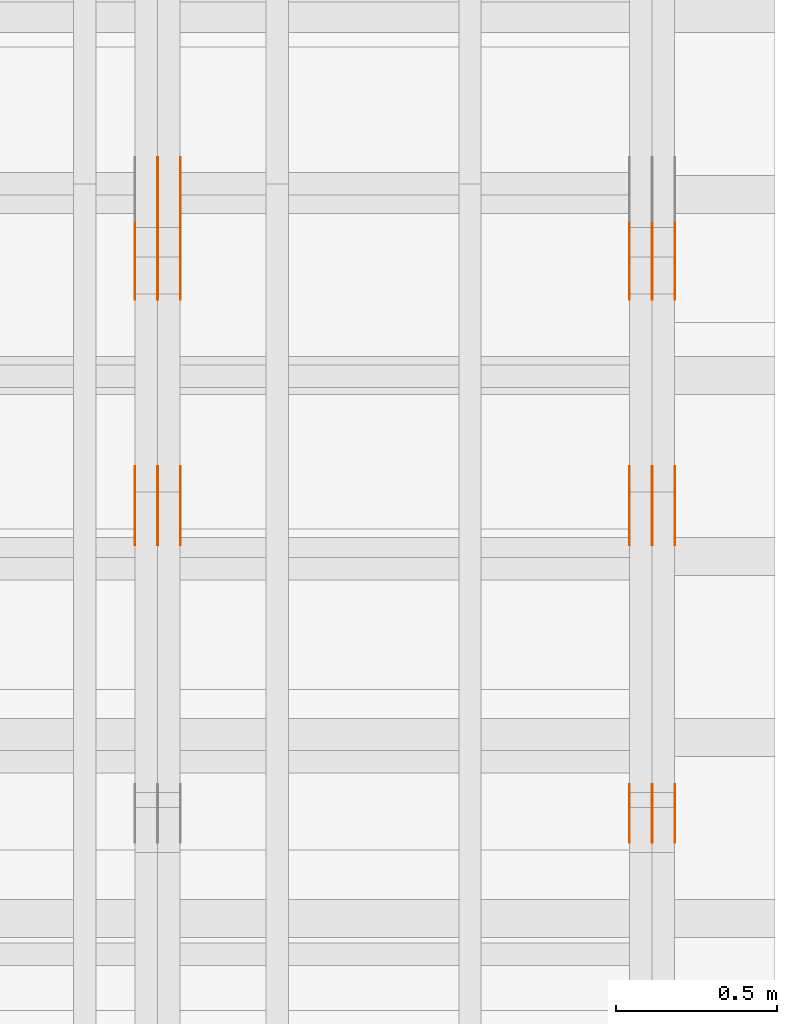
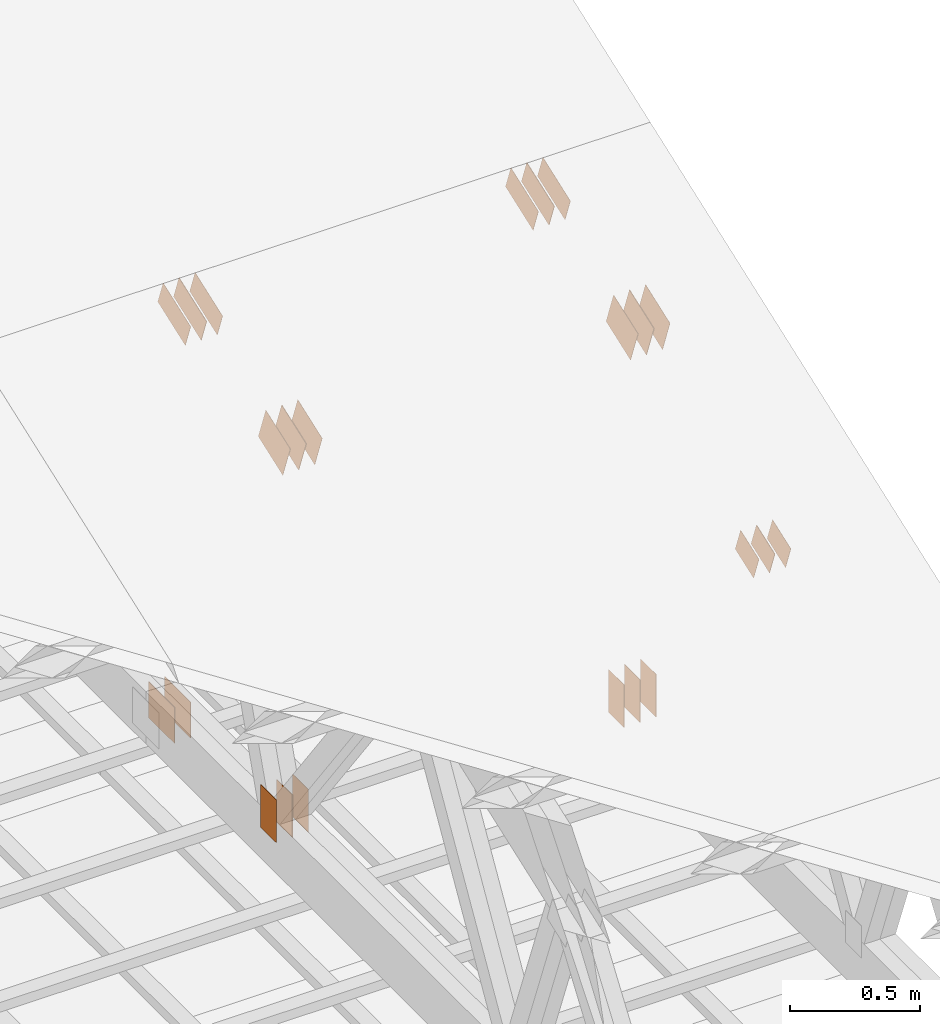
# One storey, part 155 of 189: 31 proxies.
"""IFC2X3 building model written with IfcOpenShell, lengths in millimetres."""

import ifcopenshell
import ifcopenshell.guid

model = None  # the IFC model being written
_history = None  # IfcOwnerHistory: only IFC2X3 demands one
_inside = {}  # id of a spatial element -> (the spatial element, [elements in it])
_under = {}  # id of a project, library or spatial element -> (it, [spatial elements below it])
_declared = {}  # id of a project -> (the project, [libraries it declares])
_typed = {}  # id of a type object -> (the type object, [elements of that type])
_made_of = {}  # id of a material, layer set ... -> (it, [elements and type objects made of it])


def new_model(schema):
    """Start an empty IFC model of exactly this schema.

    Asked for "IFC4X3", IfcOpenShell would pick the latest addendum, in which some entities
    have other attributes; the version numbers below select the first issue.
    IFC2X3 requires an IfcOwnerHistory on every rooted entity: one is made here for all.
    """
    global model, _history
    if schema == "IFC4X3":
        model = ifcopenshell.file(schema_version=(4, 3, 0, 0))
    else:
        model = ifcopenshell.file(schema=schema)
    _inside.clear()
    _under.clear()
    _declared.clear()
    _typed.clear()
    _made_of.clear()
    _history = None
    if model.schema == "IFC2X3":
        org = make("IfcOrganization", Name="unknown")
        user = make(
            "IfcPersonAndOrganization",
            ThePerson=make("IfcPerson", FamilyName="unknown"),
            TheOrganization=org,
        )
        app = make(
            "IfcApplication",
            ApplicationDeveloper=org,
            Version="unknown",
            ApplicationFullName="unknown",
            ApplicationIdentifier="unknown",
        )
        _history = make(
            "IfcOwnerHistory",
            OwningUser=user,
            OwningApplication=app,
            ChangeAction="ADDED",
            CreationDate=0,
        )
    return model


def make(cls, **values):
    """One entity of the class cls with the attributes given. An attribute that is None is left unset."""
    return model.create_entity(
        cls, **{name: value for name, value in values.items() if value is not None}
    )


def entity(cls, *values):
    """Any entity or typed value of the class cls, its attributes in the order of the schema. None: left unset."""
    e = model.create_entity(cls)
    for i, value in enumerate(values):
        if value is not None:
            e[i] = value
    return e


def rooted(cls, **values):
    """An entity with a GlobalId (a new one), such as an element, a storey or a relation."""
    return make(cls, GlobalId=ifcopenshell.guid.new(), OwnerHistory=_history, **values)


def si_unit(unit_type, name, prefix=None):
    """IfcSIUnit, for example si_unit("LENGTHUNIT", "METRE", prefix="MILLI")."""
    return make("IfcSIUnit", UnitType=unit_type, Prefix=prefix, Name=name)


def converted_unit(unit_type, name, factor, base, dimensions=None, offset=None):
    """IfcConversionBasedUnit, such as the inch: factor (a typed value) times the base unit."""
    return make(
        "IfcConversionBasedUnit"
        if offset is None
        else "IfcConversionBasedUnitWithOffset",
        ConversionOffset=offset,
        Dimensions=None
        if dimensions is None
        else entity("IfcDimensionalExponents", *dimensions),
        UnitType=unit_type,
        Name=name,
        ConversionFactor=make(
            "IfcMeasureWithUnit", ValueComponent=factor, UnitComponent=base
        ),
    )


def derived_unit(unit_type, elements):
    """IfcDerivedUnit: a product of units, each with its exponent."""
    return make(
        "IfcDerivedUnit",
        Elements=[
            make("IfcDerivedUnitElement", Unit=unit, Exponent=power)
            for unit, power in elements
        ],
        UnitType=unit_type,
    )


def assignment(units):
    """IfcUnitAssignment: the units of a project."""
    return None if units is None else make("IfcUnitAssignment", Units=units)


def point(xyz):
    """IfcCartesianPoint."""
    return None if xyz is None else make("IfcCartesianPoint", Coordinates=xyz)


def direction(xyz):
    """IfcDirection."""
    return None if xyz is None else make("IfcDirection", DirectionRatios=xyz)


def frame(location, z_axis=None, x_axis=None):
    """IfcAxis2Placement3D, a coordinate frame: its origin and axes. An axis left out is left unset."""
    return make(
        "IfcAxis2Placement3D",
        Location=point(location),
        Axis=direction(z_axis),
        RefDirection=direction(x_axis),
    )


def frame_2d(location, x_axis=None):
    """IfcAxis2Placement2D, a coordinate frame in the plane: its origin and x axis."""
    return make(
        "IfcAxis2Placement2D", Location=point(location), RefDirection=direction(x_axis)
    )


def origin():
    """The frame at (0, 0, 0) with its axes left unset."""
    return frame((0.0, 0.0, 0.0))


def origin_2d_with_axis():
    """The frame at (0, 0) in the plane with the x axis (1, 0) written out."""
    return frame_2d((0.0, 0.0), x_axis=(1.0, 0.0))


def place(relative_to, where):
    """IfcLocalPlacement: puts the frame where relative to a parent placement (None: the world)."""
    return make(
        "IfcLocalPlacement", PlacementRelTo=relative_to, RelativePlacement=where
    )


def context(
    kind, dimensions, precision=None, world=None, true_north=None, identifier=None
):
    """IfcGeometricRepresentationContext, for example the 3D "Model" context."""
    return make(
        "IfcGeometricRepresentationContext",
        ContextIdentifier=identifier,
        ContextType=kind,
        CoordinateSpaceDimension=dimensions,
        Precision=precision,
        WorldCoordinateSystem=world,
        TrueNorth=true_north,
    )


def subcontext(parent, identifier, kind, view, scale=None):
    """IfcGeometricRepresentationSubContext, for example "Body" below "Model"."""
    return make(
        "IfcGeometricRepresentationSubContext",
        ContextIdentifier=identifier,
        ContextType=kind,
        ParentContext=parent,
        TargetScale=scale,
        TargetView=view,
    )


def project(units=None, contexts=None):
    """IfcProject with its units and contexts."""
    return rooted(
        "IfcProject",
        Name="project",
        RepresentationContexts=contexts,
        UnitsInContext=assignment(units),
    )


def spatial(cls, under=None, at=None, **own):
    """A site, building, storey or space (cls), placed at a placement, below another one or the project."""
    s = rooted(cls, ObjectPlacement=at, **own)
    if under is not None:
        _under.setdefault(under.id(), (under, []))[1].append(s)
    return s


def polyline(points):
    """IfcPolyline through the points."""
    return make("IfcPolyline", Points=[point(p) for p in points])


def profile(cls, at=None, kind="AREA", **sizes):
    """A parametric profile (cls). Its sizes go by their IFC names, for example OverallWidth=200.0."""
    return make(cls, ProfileType=kind, Position=at, **sizes)


def rectangle(**sizes):
    """IfcRectangleProfileDef."""
    return profile("IfcRectangleProfileDef", **sizes)


def outline(outer, holes=None, kind="AREA"):
    """IfcArbitraryClosedProfileDef: a profile drawn as a closed curve; with holes, ...WithVoids."""
    if holes is None:
        return make("IfcArbitraryClosedProfileDef", ProfileType=kind, OuterCurve=outer)
    return make(
        "IfcArbitraryProfileDefWithVoids",
        ProfileType=kind,
        OuterCurve=outer,
        InnerCurves=holes,
    )


def extrude(swept, where, along, depth):
    """IfcExtrudedAreaSolid: the profile swept, set in the frame where, extruded along a direction by depth."""
    return make(
        "IfcExtrudedAreaSolid",
        SweptArea=swept,
        Position=where,
        ExtrudedDirection=direction(along),
        Depth=depth,
    )


def shape(context_of_items, identifier, shape_type, items):
    """IfcShapeRepresentation: the items that make up one representation, for example the "Body"."""
    return make(
        "IfcShapeRepresentation",
        ContextOfItems=context_of_items,
        RepresentationIdentifier=identifier,
        RepresentationType=shape_type,
        Items=items,
    )


def source(mapping_origin, context_of_items, identifier, shape_type, items):
    """IfcRepresentationMap: a shape defined once, which mapped items show again and again."""
    return make(
        "IfcRepresentationMap",
        MappingOrigin=mapping_origin,
        MappedRepresentation=shape(context_of_items, identifier, shape_type, items),
    )


def transform(
    local_origin,
    x_axis=None,
    y_axis=None,
    z_axis=None,
    scale=None,
    scale2=None,
    scale3=None,
    uniform=True,
):
    """IfcCartesianTransformationOperator3D, or its non-uniform kind. x_axis, y_axis, z_axis: its Axis1, 2, 3."""
    if uniform:
        return make(
            "IfcCartesianTransformationOperator3D",
            Axis1=direction(x_axis),
            Axis2=direction(y_axis),
            LocalOrigin=point(local_origin),
            Scale=scale,
            Axis3=direction(z_axis),
        )
    return make(
        "IfcCartesianTransformationOperator3DnonUniform",
        Axis1=direction(x_axis),
        Axis2=direction(y_axis),
        LocalOrigin=point(local_origin),
        Scale=scale,
        Axis3=direction(z_axis),
        Scale2=scale2,
        Scale3=scale3,
    )


def mapped(mapping_source, mapping_target):
    """IfcMappedItem: shows the shape of a source again, moved by a transform."""
    return make(
        "IfcMappedItem", MappingSource=mapping_source, MappingTarget=mapping_target
    )


def material(Name=None, Category=None):
    """IfcMaterial."""
    return make("IfcMaterial", Name=Name, Category=Category)


def made_of(thing, what):
    """Note that an element or type object is made of a material, layer set ...; save() writes the relation."""
    if what is not None:
        _made_of.setdefault(what.id(), (what, []))[1].append(thing)
    return thing


def type_object(cls, material=None, **own):
    """A type object (cls), such as IfcWallType, which elements share."""
    return made_of(rooted(cls, **own), material)


def type_shapes(of_type, sources):
    """Give a type object the sources (RepresentationMaps) that its elements show as mapped items."""
    of_type.RepresentationMaps = sources


def element(
    cls,
    number,
    at=None,
    inside=None,
    cuts=None,
    type_object=None,
    material=None,
    context=None,
    identifier="Body",
    shape_type=None,
    held_by="IfcProductDefinitionShape",
    body=None,
    shapes=None,
    **own,
):
    """One element of the class cls, such as IfcWall. Its Tag is "e" and its number.

    at: its placement. inside: the storey or other place that contains it. cuts: it is an
    opening in that element (IfcRelVoidsElement). A single representation is given by context,
    identifier, shape_type and body (its items); several are given by shapes. held_by: the class
    of the entity that holds the representations. save() writes the other relations.
    """
    e = rooted(cls, Tag="e%d" % number, ObjectPlacement=at, **own)
    if body is not None:
        shapes = [shape(context, identifier, shape_type, body)]
    if shapes is not None:
        e.Representation = make(held_by, Representations=shapes)
    if inside is not None:
        _inside.setdefault(inside.id(), (inside, []))[1].append(e)
    if cuts is not None:
        rooted(
            "IfcRelVoidsElement", RelatingBuildingElement=cuts, RelatedOpeningElement=e
        )
    if type_object is not None:
        _typed.setdefault(type_object.id(), (type_object, []))[1].append(e)
    return made_of(e, material)


def aggregate(whole, parts):
    """IfcRelAggregates: a whole, such as a stair, and the parts it consists of."""
    return rooted("IfcRelAggregates", RelatingObject=whole, RelatedObjects=parts)


def save(model, path):
    """Write the relations noted so far, then the file.

    IfcRelAggregates (storeys below a building ...), IfcRelContainedInSpatialStructure (elements
    in a storey), IfcRelDefinesByType, IfcRelAssociatesMaterial and IfcRelDeclares: one each for
    every whole, place, type object, material and project.
    """
    for whole, parts in _under.values():
        aggregate(whole, parts)
    for where, things in _inside.values():
        rooted(
            "IfcRelContainedInSpatialStructure",
            RelatedElements=things,
            RelatingStructure=where,
        )
    for kind, things in _typed.values():
        rooted("IfcRelDefinesByType", RelatedObjects=things, RelatingType=kind)
    for what, things in _made_of.values():
        rooted("IfcRelAssociatesMaterial", RelatedObjects=things, RelatingMaterial=what)
    for by, libraries in _declared.values():
        rooted("IfcRelDeclares", RelatingContext=by, RelatedDefinitions=libraries)
    model.write(path)


model = new_model("IFC2X3")

# Units and contexts
model_context = context("Model", 3, precision=0.01, world=origin(), true_north=direction((6.12303176911189e-17, 1.0)))
body_context = subcontext(model_context, "Body", "Model", "MODEL_VIEW")
ifc_project = project(units=[si_unit("LENGTHUNIT", "METRE", prefix="MILLI"), si_unit("AREAUNIT", "SQUARE_METRE"), si_unit("VOLUMEUNIT", "CUBIC_METRE"), converted_unit("PLANEANGLEUNIT", "DEGREE", entity("IfcRatioMeasure", 0.0174532925199433), si_unit("PLANEANGLEUNIT", "RADIAN"), dimensions=[0, 0, 0, 0, 0, 0, 0]), si_unit("MASSUNIT", "GRAM", prefix="KILO"), derived_unit("MASSDENSITYUNIT", [(si_unit("MASSUNIT", "GRAM", prefix="KILO"), 1), (si_unit("LENGTHUNIT", "METRE"), -3)]), si_unit("TIMEUNIT", "SECOND"), si_unit("FREQUENCYUNIT", "HERTZ"), si_unit("THERMODYNAMICTEMPERATUREUNIT", "DEGREE_CELSIUS"), derived_unit("THERMALTRANSMITTANCEUNIT", [(si_unit("MASSUNIT", "GRAM", prefix="KILO"), 1), (si_unit("THERMODYNAMICTEMPERATUREUNIT", "KELVIN"), -1), (si_unit("TIMEUNIT", "SECOND"), -3)]), derived_unit("VOLUMETRICFLOWRATEUNIT", [(si_unit("LENGTHUNIT", "METRE"), 3), (si_unit("TIMEUNIT", "SECOND"), -1)]), si_unit("ELECTRICCURRENTUNIT", "AMPERE"), si_unit("ELECTRICVOLTAGEUNIT", "VOLT"), si_unit("POWERUNIT", "WATT"), si_unit("FORCEUNIT", "NEWTON"), si_unit("ILLUMINANCEUNIT", "LUX"), si_unit("LUMINOUSFLUXUNIT", "LUMEN"), si_unit("LUMINOUSINTENSITYUNIT", "CANDELA"), derived_unit("USERDEFINED", [(si_unit("MASSUNIT", "GRAM", prefix="KILO"), -1), (si_unit("LENGTHUNIT", "METRE"), -2), (si_unit("TIMEUNIT", "SECOND"), 3), (si_unit("LUMINOUSFLUXUNIT", "LUMEN"), 1)]), derived_unit("LINEARVELOCITYUNIT", [(si_unit("LENGTHUNIT", "METRE"), 1), (si_unit("TIMEUNIT", "SECOND"), -1)]), si_unit("PRESSUREUNIT", "PASCAL"), derived_unit("USERDEFINED", [(si_unit("LENGTHUNIT", "METRE"), -2), (si_unit("MASSUNIT", "GRAM", prefix="KILO"), 1), (si_unit("TIMEUNIT", "SECOND"), -2)])], contexts=[model_context])

# Site, building, storey
site_placement = place(None, origin())
site = spatial("IfcSite", under=ifc_project, at=site_placement, CompositionType="ELEMENT")
building_placement = place(site_placement, origin())
building = spatial("IfcBuilding", under=site, at=building_placement, CompositionType="ELEMENT")
storey_placement = place(building_placement, origin())
storey = spatial("IfcBuildingStorey", under=building, at=storey_placement, Name="Default", CompositionType="ELEMENT", Elevation=0.0)

# Proxies
ifc_material_1 = material(Name="IfcSurfaceStyle #280396")
building_element_proxy_type_1 = type_object("IfcBuildingElementProxyType", PredefinedType="NOTDEFINED", material=ifc_material_1)
shared_shape_1 = source(origin(), body_context, "Body", "SweptSolid", [
    extrude(outline(polyline([(-112.500654374667, -59.9999021691247), (112.500117969231, -59.9999021691247), (112.500612624162, 59.9999021691247), (-112.500076218726, 59.9999021691247), (-112.500654374667, -59.9999021691247)])), frame((112.500612624162, 60.0003514046321, 0.0), z_axis=(0.0, 0.0, 1.0), x_axis=(-1.0, 0.0, 0.0)), (0.0, 0.0, 1.0), 1.3),
])
type_shapes(building_element_proxy_type_1, [shared_shape_1])
proxy_1_placement = place(building_placement, frame((49841.3, 5418.0703125, 2162.37353515625), z_axis=(-1.0, 0.0, 0.0), x_axis=(0.0, 0.939692620785908, 0.342020143325669)))
element("IfcBuildingElementProxy", 1, at=proxy_1_placement, inside=storey, type_object=building_element_proxy_type_1, material=ifc_material_1, context=body_context, shape_type="MappedRepresentation", body=[
    mapped(shared_shape_1, transform((0.0, 0.0, 0.0), scale=1.0)),
])
ifc_material_2 = material(Name="IfcSurfaceStyle #280339")
building_element_proxy_type_2 = type_object("IfcBuildingElementProxyType", PredefinedType="NOTDEFINED", material=ifc_material_2)
shared_shape_2 = source(origin(), body_context, "Body", "SweptSolid", [
    extrude(outline(polyline([(-112.500654374667, -59.9999021691247), (112.500117969231, -59.9999021691247), (112.500612624162, 59.9999021691247), (-112.500076218726, 59.9999021691247), (-112.500654374667, -59.9999021691247)])), frame((112.500612624162, 60.0003514046321, 0.0), z_axis=(0.0, 0.0, 1.0), x_axis=(-1.0, 0.0, 0.0)), (0.0, 0.0, 1.0), 1.29999999999998),
])
type_shapes(building_element_proxy_type_2, [shared_shape_2])
proxy_2_placement = place(building_placement, frame((49770.0, 5418.0703125, 2162.37353515625), z_axis=(-1.0, 0.0, 0.0), x_axis=(0.0, 0.939692620785908, 0.342020143325669)))
element("IfcBuildingElementProxy", 2, at=proxy_2_placement, inside=storey, type_object=building_element_proxy_type_2, material=ifc_material_2, context=body_context, shape_type="MappedRepresentation", body=[
    mapped(shared_shape_2, transform((0.0, 0.0, 0.0), scale=1.0)),
])
ifc_material_3 = material(Name="IfcSurfaceStyle #280282")
building_element_proxy_type_3 = type_object("IfcBuildingElementProxyType", PredefinedType="NOTDEFINED", material=ifc_material_3)
shared_shape_3 = source(origin(), body_context, "Body", "SweptSolid", [
    extrude(outline(polyline([(-112.500654374667, -59.9999021691247), (112.500117969231, -59.9999021691247), (112.500612624162, 59.9999021691247), (-112.500076218726, 59.9999021691247), (-112.500654374667, -59.9999021691247)])), frame((112.500612624162, 60.0003514046321, 0.0), z_axis=(0.0, 0.0, 1.0), x_axis=(-1.0, 0.0, 0.0)), (0.0, 0.0, 1.0), 1.29999999999998),
])
type_shapes(building_element_proxy_type_3, [shared_shape_3])
proxy_3_placement = place(building_placement, frame((49771.3, 5418.0703125, 2162.37353515625), z_axis=(-1.0, 0.0, 0.0), x_axis=(0.0, 0.939692620785908, 0.342020143325669)))
element("IfcBuildingElementProxy", 3, at=proxy_3_placement, inside=storey, type_object=building_element_proxy_type_3, material=ifc_material_3, context=body_context, shape_type="MappedRepresentation", body=[
    mapped(shared_shape_3, transform((0.0, 0.0, 0.0), scale=1.0)),
])
ifc_material_4 = material(Name="IfcSurfaceStyle #280225")
building_element_proxy_type_4 = type_object("IfcBuildingElementProxyType", PredefinedType="NOTDEFINED", material=ifc_material_4)
shared_shape_4 = source(origin(), body_context, "Body", "SweptSolid", [
    extrude(outline(polyline([(-112.500654374667, -59.9999021691247), (112.500117969231, -59.9999021691247), (112.500612624162, 59.9999021691247), (-112.500076218726, 59.9999021691247), (-112.500654374667, -59.9999021691247)])), frame((112.500612624162, 60.0003514046321, 0.0), z_axis=(0.0, 0.0, 1.0), x_axis=(-1.0, 0.0, 0.0)), (0.0, 0.0, 1.0), 1.29999999999999),
])
type_shapes(building_element_proxy_type_4, [shared_shape_4])
proxy_4_placement = place(building_placement, frame((49700.0, 5418.0703125, 2162.37353515625), z_axis=(-1.0, 0.0, 0.0), x_axis=(0.0, 0.939692620785908, 0.342020143325669)))
element("IfcBuildingElementProxy", 4, at=proxy_4_placement, inside=storey, type_object=building_element_proxy_type_4, material=ifc_material_4, context=body_context, shape_type="MappedRepresentation", body=[
    mapped(shared_shape_4, transform((0.0, 0.0, 0.0), scale=1.0)),
])
ifc_material_5 = material(Name="IfcSurfaceStyle #279712")
building_element_proxy_type_5 = type_object("IfcBuildingElementProxyType", PredefinedType="NOTDEFINED", material=ifc_material_5)
shared_shape_5 = source(origin(), body_context, "Body", "SweptSolid", [
    extrude(rectangle(XDim=200.0, YDim=120.0, at=origin_2d_with_axis()), frame((100.0, 60.0, 0.0), z_axis=(0.0, 0.0, 1.0), x_axis=(-1.0, 0.0, 0.0)), (0.0, 0.0, 1.0), 1.3),
])
type_shapes(building_element_proxy_type_5, [shared_shape_5])
proxy_5_placement = place(building_placement, frame((49841.3, 4760.65625, 145.0), z_axis=(-1.0, 0.0, 0.0), x_axis=(0.0, 0.0, 1.0)))
element("IfcBuildingElementProxy", 5, at=proxy_5_placement, inside=storey, type_object=building_element_proxy_type_5, material=ifc_material_5, context=body_context, shape_type="MappedRepresentation", body=[
    mapped(shared_shape_5, transform((0.0, 0.0, 0.0), scale=1.0)),
])
ifc_material_6 = material(Name="IfcSurfaceStyle #279655")
building_element_proxy_type_6 = type_object("IfcBuildingElementProxyType", PredefinedType="NOTDEFINED", material=ifc_material_6)
shared_shape_6 = source(origin(), body_context, "Body", "SweptSolid", [
    extrude(rectangle(XDim=200.0, YDim=120.0, at=origin_2d_with_axis()), frame((100.0, 60.0, 0.0), z_axis=(0.0, 0.0, 1.0), x_axis=(-1.0, 0.0, 0.0)), (0.0, 0.0, 1.0), 1.29999999999998),
])
type_shapes(building_element_proxy_type_6, [shared_shape_6])
proxy_6_placement = place(building_placement, frame((49770.0, 4760.65625, 145.0), z_axis=(-1.0, 0.0, 0.0), x_axis=(0.0, 0.0, 1.0)))
element("IfcBuildingElementProxy", 6, at=proxy_6_placement, inside=storey, type_object=building_element_proxy_type_6, material=ifc_material_6, context=body_context, shape_type="MappedRepresentation", body=[
    mapped(shared_shape_6, transform((0.0, 0.0, 0.0), scale=1.0)),
])
ifc_material_7 = material(Name="IfcSurfaceStyle #279598")
building_element_proxy_type_7 = type_object("IfcBuildingElementProxyType", PredefinedType="NOTDEFINED", material=ifc_material_7)
shared_shape_7 = source(origin(), body_context, "Body", "SweptSolid", [
    extrude(rectangle(XDim=200.0, YDim=120.0, at=origin_2d_with_axis()), frame((100.0, 60.0, 0.0), z_axis=(0.0, 0.0, 1.0), x_axis=(-1.0, 0.0, 0.0)), (0.0, 0.0, 1.0), 1.29999999999998),
])
type_shapes(building_element_proxy_type_7, [shared_shape_7])
proxy_7_placement = place(building_placement, frame((49771.3, 4760.65625, 145.0), z_axis=(-1.0, 0.0, 0.0), x_axis=(0.0, 0.0, 1.0)))
element("IfcBuildingElementProxy", 7, at=proxy_7_placement, inside=storey, type_object=building_element_proxy_type_7, material=ifc_material_7, context=body_context, shape_type="MappedRepresentation", body=[
    mapped(shared_shape_7, transform((0.0, 0.0, 0.0), scale=1.0)),
])
ifc_material_8 = material(Name="IfcSurfaceStyle #279541")
building_element_proxy_type_8 = type_object("IfcBuildingElementProxyType", PredefinedType="NOTDEFINED", material=ifc_material_8)
shared_shape_8 = source(origin(), body_context, "Body", "SweptSolid", [
    extrude(rectangle(XDim=200.0, YDim=120.0, at=origin_2d_with_axis()), frame((100.0, 60.0, 0.0), z_axis=(0.0, 0.0, 1.0), x_axis=(-1.0, 0.0, 0.0)), (0.0, 0.0, 1.0), 1.29999999999999),
])
type_shapes(building_element_proxy_type_8, [shared_shape_8])
proxy_8_placement = place(building_placement, frame((49700.0, 4760.65625, 145.0), z_axis=(-1.0, 0.0, 0.0), x_axis=(0.0, 0.0, 1.0)))
element("IfcBuildingElementProxy", 8, at=proxy_8_placement, inside=storey, type_object=building_element_proxy_type_8, material=ifc_material_8, context=body_context, shape_type="MappedRepresentation", body=[
    mapped(shared_shape_8, transform((0.0, 0.0, 0.0), scale=1.0)),
])
ifc_material_9 = material(Name="IfcSurfaceStyle #279484")
building_element_proxy_type_9 = type_object("IfcBuildingElementProxyType", PredefinedType="NOTDEFINED", material=ifc_material_9)
shared_shape_9 = source(origin(), body_context, "Body", "SweptSolid", [
    extrude(outline(polyline([(-74.9994515581384, -59.9999039432178), (74.9998536965286, -59.9999039432178), (75.0003483514593, 59.9999039432178), (-75.0007504898495, 59.9999039432178), (-74.9994515581384, -59.9999039432178)])), frame((75.0003483514593, 60.0003496305408, 0.0), z_axis=(0.0, 0.0, 1.0), x_axis=(-1.0, 0.0, 0.0)), (0.0, 0.0, 1.0), 1.3),
])
type_shapes(building_element_proxy_type_9, [shared_shape_9])
proxy_9_placement = place(building_placement, frame((49841.3, 3726.8984375, 1559.607421875), z_axis=(-1.0, 0.0, 0.0), x_axis=(0.0, 0.939692620785908, 0.342020143325669)))
element("IfcBuildingElementProxy", 9, at=proxy_9_placement, inside=storey, type_object=building_element_proxy_type_9, material=ifc_material_9, context=body_context, shape_type="MappedRepresentation", body=[
    mapped(shared_shape_9, transform((0.0, 0.0, 0.0), scale=1.0)),
])
ifc_material_10 = material(Name="IfcSurfaceStyle #279427")
building_element_proxy_type_10 = type_object("IfcBuildingElementProxyType", PredefinedType="NOTDEFINED", material=ifc_material_10)
shared_shape_10 = source(origin(), body_context, "Body", "SweptSolid", [
    extrude(outline(polyline([(-74.9994515581384, -59.9999039432178), (74.9998536965286, -59.9999039432178), (75.0003483514593, 59.9999039432178), (-75.0007504898495, 59.9999039432178), (-74.9994515581384, -59.9999039432178)])), frame((75.0003483514593, 60.0003496305408, 0.0), z_axis=(0.0, 0.0, 1.0), x_axis=(-1.0, 0.0, 0.0)), (0.0, 0.0, 1.0), 1.29999999999999),
])
type_shapes(building_element_proxy_type_10, [shared_shape_10])
proxy_10_placement = place(building_placement, frame((49770.0, 3726.8984375, 1559.607421875), z_axis=(-1.0, 0.0, 0.0), x_axis=(0.0, 0.939692620785908, 0.342020143325669)))
element("IfcBuildingElementProxy", 10, at=proxy_10_placement, inside=storey, type_object=building_element_proxy_type_10, material=ifc_material_10, context=body_context, shape_type="MappedRepresentation", body=[
    mapped(shared_shape_10, transform((0.0, 0.0, 0.0), scale=1.0)),
])
ifc_material_11 = material(Name="IfcSurfaceStyle #279370")
building_element_proxy_type_11 = type_object("IfcBuildingElementProxyType", PredefinedType="NOTDEFINED", material=ifc_material_11)
shared_shape_11 = source(origin(), body_context, "Body", "SweptSolid", [
    extrude(outline(polyline([(-74.9994515581384, -59.9999039432178), (74.9998536965286, -59.9999039432178), (75.0003483514593, 59.9999039432178), (-75.0007504898495, 59.9999039432178), (-74.9994515581384, -59.9999039432178)])), frame((75.0003483514593, 60.0003496305408, 0.0), z_axis=(0.0, 0.0, 1.0), x_axis=(-1.0, 0.0, 0.0)), (0.0, 0.0, 1.0), 1.29999999999999),
])
type_shapes(building_element_proxy_type_11, [shared_shape_11])
proxy_11_placement = place(building_placement, frame((49771.3, 3726.8984375, 1559.607421875), z_axis=(-1.0, 0.0, 0.0), x_axis=(0.0, 0.939692620785908, 0.342020143325669)))
element("IfcBuildingElementProxy", 11, at=proxy_11_placement, inside=storey, type_object=building_element_proxy_type_11, material=ifc_material_11, context=body_context, shape_type="MappedRepresentation", body=[
    mapped(shared_shape_11, transform((0.0, 0.0, 0.0), scale=1.0)),
])
ifc_material_12 = material(Name="IfcSurfaceStyle #279313")
building_element_proxy_type_12 = type_object("IfcBuildingElementProxyType", PredefinedType="NOTDEFINED", material=ifc_material_12)
shared_shape_12 = source(origin(), body_context, "Body", "SweptSolid", [
    extrude(outline(polyline([(-74.9994515581384, -59.9999039432178), (74.9998536965286, -59.9999039432178), (75.0003483514593, 59.9999039432178), (-75.0007504898495, 59.9999039432178), (-74.9994515581384, -59.9999039432178)])), frame((75.0003483514593, 60.0003496305408, 0.0), z_axis=(0.0, 0.0, 1.0), x_axis=(-1.0, 0.0, 0.0)), (0.0, 0.0, 1.0), 1.29999999999999),
])
type_shapes(building_element_proxy_type_12, [shared_shape_12])
proxy_12_placement = place(building_placement, frame((49700.0, 3726.8984375, 1559.607421875), z_axis=(-1.0, 0.0, 0.0), x_axis=(0.0, 0.939692620785908, 0.342020143325669)))
element("IfcBuildingElementProxy", 12, at=proxy_12_placement, inside=storey, type_object=building_element_proxy_type_12, material=ifc_material_12, context=body_context, shape_type="MappedRepresentation", body=[
    mapped(shared_shape_12, transform((0.0, 0.0, 0.0), scale=1.0)),
])
ifc_material_13 = material(Name="IfcSurfaceStyle #274816")
building_element_proxy_type_13 = type_object("IfcBuildingElementProxyType", PredefinedType="NOTDEFINED", material=ifc_material_13)
shared_shape_13 = source(origin(), body_context, "Body", "SweptSolid", [
    extrude(outline(polyline([(-99.9993269270171, -84.0000832532405), (99.9997189122032, -84.0000832532405), (99.9992851765118, 84.0000832532405), (-99.999677161698, 84.0000832532405), (-99.9993269270171, -84.0000832532405)])), frame((99.9999283659736, 84.0000832532405, 0.0), z_axis=(0.0, 0.0, 1.0), x_axis=(-1.0, 0.0, 0.0)), (0.0, 0.0, 1.0), 1.3),
])
type_shapes(building_element_proxy_type_13, [shared_shape_13])
proxy_13_placement = place(building_placement, frame((49841.3, 4654.06379965055, 2052.96988554922), z_axis=(-1.0, 0.0, 0.0), x_axis=(0.0, 0.939692620785908, 0.342020143325669)))
element("IfcBuildingElementProxy", 13, at=proxy_13_placement, inside=storey, type_object=building_element_proxy_type_13, material=ifc_material_13, context=body_context, shape_type="MappedRepresentation", body=[
    mapped(shared_shape_13, transform((0.0, 0.0, 0.0), scale=1.0)),
])
ifc_material_14 = material(Name="IfcSurfaceStyle #274759")
building_element_proxy_type_14 = type_object("IfcBuildingElementProxyType", PredefinedType="NOTDEFINED", material=ifc_material_14)
shared_shape_14 = source(origin(), body_context, "Body", "SweptSolid", [
    extrude(outline(polyline([(-99.9993269270171, -84.0000832532405), (99.9997189122032, -84.0000832532405), (99.9992851765118, 84.0000832532405), (-99.999677161698, 84.0000832532405), (-99.9993269270171, -84.0000832532405)])), frame((99.9999283659736, 84.0000832532405, 0.0), z_axis=(0.0, 0.0, 1.0), x_axis=(-1.0, 0.0, 0.0)), (0.0, 0.0, 1.0), 1.29999999999998),
])
type_shapes(building_element_proxy_type_14, [shared_shape_14])
proxy_14_placement = place(building_placement, frame((49770.0, 4654.06379965055, 2052.96988554922), z_axis=(-1.0, 0.0, 0.0), x_axis=(0.0, 0.939692620785908, 0.342020143325669)))
element("IfcBuildingElementProxy", 14, at=proxy_14_placement, inside=storey, type_object=building_element_proxy_type_14, material=ifc_material_14, context=body_context, shape_type="MappedRepresentation", body=[
    mapped(shared_shape_14, transform((0.0, 0.0, 0.0), scale=1.0)),
])
ifc_material_15 = material(Name="IfcSurfaceStyle #274702")
building_element_proxy_type_15 = type_object("IfcBuildingElementProxyType", PredefinedType="NOTDEFINED", material=ifc_material_15)
shared_shape_15 = source(origin(), body_context, "Body", "SweptSolid", [
    extrude(outline(polyline([(-99.9993269270171, -84.0000832532405), (99.9997189122032, -84.0000832532405), (99.9992851765118, 84.0000832532405), (-99.999677161698, 84.0000832532405), (-99.9993269270171, -84.0000832532405)])), frame((99.9999283659736, 84.0000832532405, 0.0), z_axis=(0.0, 0.0, 1.0), x_axis=(-1.0, 0.0, 0.0)), (0.0, 0.0, 1.0), 1.29999999999998),
])
type_shapes(building_element_proxy_type_15, [shared_shape_15])
proxy_15_placement = place(building_placement, frame((49771.3, 4654.06379965055, 2052.96988554922), z_axis=(-1.0, 0.0, 0.0), x_axis=(0.0, 0.939692620785908, 0.342020143325669)))
element("IfcBuildingElementProxy", 15, at=proxy_15_placement, inside=storey, type_object=building_element_proxy_type_15, material=ifc_material_15, context=body_context, shape_type="MappedRepresentation", body=[
    mapped(shared_shape_15, transform((0.0, 0.0, 0.0), scale=1.0)),
])
ifc_material_16 = material(Name="IfcSurfaceStyle #274645")
building_element_proxy_type_16 = type_object("IfcBuildingElementProxyType", PredefinedType="NOTDEFINED", material=ifc_material_16)
shared_shape_16 = source(origin(), body_context, "Body", "SweptSolid", [
    extrude(outline(polyline([(-99.9993269270171, -84.0000832532405), (99.9997189122032, -84.0000832532405), (99.9992851765118, 84.0000832532405), (-99.999677161698, 84.0000832532405), (-99.9993269270171, -84.0000832532405)])), frame((99.9999283659736, 84.0000832532405, 0.0), z_axis=(0.0, 0.0, 1.0), x_axis=(-1.0, 0.0, 0.0)), (0.0, 0.0, 1.0), 1.29999999999999),
])
type_shapes(building_element_proxy_type_16, [shared_shape_16])
proxy_16_placement = place(building_placement, frame((49700.0, 4654.06379965055, 2052.96988554922), z_axis=(-1.0, 0.0, 0.0), x_axis=(0.0, 0.939692620785908, 0.342020143325669)))
element("IfcBuildingElementProxy", 16, at=proxy_16_placement, inside=storey, type_object=building_element_proxy_type_16, material=ifc_material_16, context=body_context, shape_type="MappedRepresentation", body=[
    mapped(shared_shape_16, transform((0.0, 0.0, 0.0), scale=1.0)),
])
ifc_material_17 = material(Name="IfcSurfaceStyle #268254")
building_element_proxy_type_17 = type_object("IfcBuildingElementProxyType", PredefinedType="NOTDEFINED", material=ifc_material_17)
shared_shape_17 = source(origin(), body_context, "Body", "SweptSolid", [
    extrude(rectangle(XDim=200.0, YDim=168.0, at=origin_2d_with_axis()), frame((100.0, 84.0, 0.0), z_axis=(0.0, 0.0, 1.0), x_axis=(-1.0, 0.0, 0.0)), (0.0, 0.0, 1.0), 1.3),
])
type_shapes(building_element_proxy_type_17, [shared_shape_17])
proxy_17_placement = place(building_placement, frame((48301.3, 5662.466796875, 206.5), z_axis=(-1.0, 0.0, 0.0), x_axis=(0.0, 1.0, 0.0)))
element("IfcBuildingElementProxy", 17, at=proxy_17_placement, inside=storey, type_object=building_element_proxy_type_17, material=ifc_material_17, context=body_context, shape_type="MappedRepresentation", body=[
    mapped(shared_shape_17, transform((0.0, 0.0, 0.0), scale=1.0)),
])
ifc_material_18 = material(Name="IfcSurfaceStyle #268197")
building_element_proxy_type_18 = type_object("IfcBuildingElementProxyType", PredefinedType="NOTDEFINED", material=ifc_material_18)
shared_shape_18 = source(origin(), body_context, "Body", "SweptSolid", [
    extrude(rectangle(XDim=200.0, YDim=168.0, at=origin_2d_with_axis()), frame((100.0, 84.0, 0.0), z_axis=(0.0, 0.0, 1.0), x_axis=(-1.0, 0.0, 0.0)), (0.0, 0.0, 1.0), 1.29999999999998),
])
type_shapes(building_element_proxy_type_18, [shared_shape_18])
proxy_18_placement = place(building_placement, frame((48230.0, 5662.466796875, 206.5), z_axis=(-1.0, 0.0, 0.0), x_axis=(0.0, 1.0, 0.0)))
element("IfcBuildingElementProxy", 18, at=proxy_18_placement, inside=storey, type_object=building_element_proxy_type_18, material=ifc_material_18, context=body_context, shape_type="MappedRepresentation", body=[
    mapped(shared_shape_18, transform((0.0, 0.0, 0.0), scale=1.0)),
])
ifc_material_19 = material(Name="IfcSurfaceStyle #268140")
building_element_proxy_type_19 = type_object("IfcBuildingElementProxyType", PredefinedType="NOTDEFINED", material=ifc_material_19)
shared_shape_19 = source(origin(), body_context, "Body", "SweptSolid", [
    extrude(rectangle(XDim=200.0, YDim=168.0, at=origin_2d_with_axis()), frame((100.0, 84.0, 0.0), z_axis=(0.0, 0.0, 1.0), x_axis=(-1.0, 0.0, 0.0)), (0.0, 0.0, 1.0), 1.29999999999998),
])
type_shapes(building_element_proxy_type_19, [shared_shape_19])
proxy_19_placement = place(building_placement, frame((48231.3, 5662.466796875, 206.5), z_axis=(-1.0, 0.0, 0.0), x_axis=(0.0, 1.0, 0.0)))
element("IfcBuildingElementProxy", 19, at=proxy_19_placement, inside=storey, type_object=building_element_proxy_type_19, material=ifc_material_19, context=body_context, shape_type="MappedRepresentation", body=[
    mapped(shared_shape_19, transform((0.0, 0.0, 0.0), scale=1.0)),
])
ifc_material_20 = material(Name="IfcSurfaceStyle #264606")
building_element_proxy_type_20 = type_object("IfcBuildingElementProxyType", PredefinedType="NOTDEFINED", material=ifc_material_20)
shared_shape_20 = source(origin(), body_context, "Body", "SweptSolid", [
    extrude(outline(polyline([(-112.500654374667, -59.9999021691247), (112.500117969231, -59.9999021691247), (112.500612624162, 59.9999021691247), (-112.500076218726, 59.9999021691247), (-112.500654374667, -59.9999021691247)])), frame((112.500612624162, 60.0003514046321, 0.0), z_axis=(0.0, 0.0, 1.0), x_axis=(-1.0, 0.0, 0.0)), (0.0, 0.0, 1.0), 1.3),
])
type_shapes(building_element_proxy_type_20, [shared_shape_20])
proxy_20_placement = place(building_placement, frame((48301.3, 5418.0703125, 2162.37353515625), z_axis=(-1.0, 0.0, 0.0), x_axis=(0.0, 0.939692620785908, 0.342020143325669)))
element("IfcBuildingElementProxy", 20, at=proxy_20_placement, inside=storey, type_object=building_element_proxy_type_20, material=ifc_material_20, context=body_context, shape_type="MappedRepresentation", body=[
    mapped(shared_shape_20, transform((0.0, 0.0, 0.0), scale=1.0)),
])
ifc_material_21 = material(Name="IfcSurfaceStyle #264549")
building_element_proxy_type_21 = type_object("IfcBuildingElementProxyType", PredefinedType="NOTDEFINED", material=ifc_material_21)
shared_shape_21 = source(origin(), body_context, "Body", "SweptSolid", [
    extrude(outline(polyline([(-112.500654374667, -59.9999021691247), (112.500117969231, -59.9999021691247), (112.500612624162, 59.9999021691247), (-112.500076218726, 59.9999021691247), (-112.500654374667, -59.9999021691247)])), frame((112.500612624162, 60.0003514046321, 0.0), z_axis=(0.0, 0.0, 1.0), x_axis=(-1.0, 0.0, 0.0)), (0.0, 0.0, 1.0), 1.29999999999998),
])
type_shapes(building_element_proxy_type_21, [shared_shape_21])
proxy_21_placement = place(building_placement, frame((48230.0, 5418.0703125, 2162.37353515625), z_axis=(-1.0, 0.0, 0.0), x_axis=(0.0, 0.939692620785908, 0.342020143325669)))
element("IfcBuildingElementProxy", 21, at=proxy_21_placement, inside=storey, type_object=building_element_proxy_type_21, material=ifc_material_21, context=body_context, shape_type="MappedRepresentation", body=[
    mapped(shared_shape_21, transform((0.0, 0.0, 0.0), scale=1.0)),
])
ifc_material_22 = material(Name="IfcSurfaceStyle #264492")
building_element_proxy_type_22 = type_object("IfcBuildingElementProxyType", PredefinedType="NOTDEFINED", material=ifc_material_22)
shared_shape_22 = source(origin(), body_context, "Body", "SweptSolid", [
    extrude(outline(polyline([(-112.500654374667, -59.9999021691247), (112.500117969231, -59.9999021691247), (112.500612624162, 59.9999021691247), (-112.500076218726, 59.9999021691247), (-112.500654374667, -59.9999021691247)])), frame((112.500612624162, 60.0003514046321, 0.0), z_axis=(0.0, 0.0, 1.0), x_axis=(-1.0, 0.0, 0.0)), (0.0, 0.0, 1.0), 1.29999999999998),
])
type_shapes(building_element_proxy_type_22, [shared_shape_22])
proxy_22_placement = place(building_placement, frame((48231.3, 5418.0703125, 2162.37353515625), z_axis=(-1.0, 0.0, 0.0), x_axis=(0.0, 0.939692620785908, 0.342020143325669)))
element("IfcBuildingElementProxy", 22, at=proxy_22_placement, inside=storey, type_object=building_element_proxy_type_22, material=ifc_material_22, context=body_context, shape_type="MappedRepresentation", body=[
    mapped(shared_shape_22, transform((0.0, 0.0, 0.0), scale=1.0)),
])
ifc_material_23 = material(Name="IfcSurfaceStyle #264435")
building_element_proxy_type_23 = type_object("IfcBuildingElementProxyType", PredefinedType="NOTDEFINED", material=ifc_material_23)
shared_shape_23 = source(origin(), body_context, "Body", "SweptSolid", [
    extrude(outline(polyline([(-112.500654374667, -59.9999021691247), (112.500117969231, -59.9999021691247), (112.500612624162, 59.9999021691247), (-112.500076218726, 59.9999021691247), (-112.500654374667, -59.9999021691247)])), frame((112.500612624162, 60.0003514046321, 0.0), z_axis=(0.0, 0.0, 1.0), x_axis=(-1.0, 0.0, 0.0)), (0.0, 0.0, 1.0), 1.29999999999999),
])
type_shapes(building_element_proxy_type_23, [shared_shape_23])
proxy_23_placement = place(building_placement, frame((48160.0, 5418.0703125, 2162.37353515625), z_axis=(-1.0, 0.0, 0.0), x_axis=(0.0, 0.939692620785908, 0.342020143325669)))
element("IfcBuildingElementProxy", 23, at=proxy_23_placement, inside=storey, type_object=building_element_proxy_type_23, material=ifc_material_23, context=body_context, shape_type="MappedRepresentation", body=[
    mapped(shared_shape_23, transform((0.0, 0.0, 0.0), scale=1.0)),
])
ifc_material_24 = material(Name="IfcSurfaceStyle #263922")
building_element_proxy_type_24 = type_object("IfcBuildingElementProxyType", PredefinedType="NOTDEFINED", material=ifc_material_24)
shared_shape_24 = source(origin(), body_context, "Body", "SweptSolid", [
    extrude(rectangle(XDim=200.0, YDim=120.0, at=origin_2d_with_axis()), frame((100.0, 60.0, 0.0), z_axis=(0.0, 0.0, 1.0), x_axis=(-1.0, 0.0, 0.0)), (0.0, 0.0, 1.0), 1.3),
])
type_shapes(building_element_proxy_type_24, [shared_shape_24])
proxy_24_placement = place(building_placement, frame((48301.3, 4760.65625, 145.0), z_axis=(-1.0, 0.0, 0.0), x_axis=(0.0, 0.0, 1.0)))
element("IfcBuildingElementProxy", 24, at=proxy_24_placement, inside=storey, type_object=building_element_proxy_type_24, material=ifc_material_24, context=body_context, shape_type="MappedRepresentation", body=[
    mapped(shared_shape_24, transform((0.0, 0.0, 0.0), scale=1.0)),
])
ifc_material_25 = material(Name="IfcSurfaceStyle #263865")
building_element_proxy_type_25 = type_object("IfcBuildingElementProxyType", PredefinedType="NOTDEFINED", material=ifc_material_25)
shared_shape_25 = source(origin(), body_context, "Body", "SweptSolid", [
    extrude(rectangle(XDim=200.0, YDim=120.0, at=origin_2d_with_axis()), frame((100.0, 60.0, 0.0), z_axis=(0.0, 0.0, 1.0), x_axis=(-1.0, 0.0, 0.0)), (0.0, 0.0, 1.0), 1.29999999999998),
])
type_shapes(building_element_proxy_type_25, [shared_shape_25])
proxy_25_placement = place(building_placement, frame((48230.0, 4760.65625, 145.0), z_axis=(-1.0, 0.0, 0.0), x_axis=(0.0, 0.0, 1.0)))
element("IfcBuildingElementProxy", 25, at=proxy_25_placement, inside=storey, type_object=building_element_proxy_type_25, material=ifc_material_25, context=body_context, shape_type="MappedRepresentation", body=[
    mapped(shared_shape_25, transform((0.0, 0.0, 0.0), scale=1.0)),
])
ifc_material_26 = material(Name="IfcSurfaceStyle #263808")
building_element_proxy_type_26 = type_object("IfcBuildingElementProxyType", PredefinedType="NOTDEFINED", material=ifc_material_26)
shared_shape_26 = source(origin(), body_context, "Body", "SweptSolid", [
    extrude(rectangle(XDim=200.0, YDim=120.0, at=origin_2d_with_axis()), frame((100.0, 60.0, 0.0), z_axis=(0.0, 0.0, 1.0), x_axis=(-1.0, 0.0, 0.0)), (0.0, 0.0, 1.0), 1.29999999999998),
])
type_shapes(building_element_proxy_type_26, [shared_shape_26])
proxy_26_placement = place(building_placement, frame((48231.3, 4760.65625, 145.0), z_axis=(-1.0, 0.0, 0.0), x_axis=(0.0, 0.0, 1.0)))
element("IfcBuildingElementProxy", 26, at=proxy_26_placement, inside=storey, type_object=building_element_proxy_type_26, material=ifc_material_26, context=body_context, shape_type="MappedRepresentation", body=[
    mapped(shared_shape_26, transform((0.0, 0.0, 0.0), scale=1.0)),
])
ifc_material_27 = material(Name="IfcSurfaceStyle #263751")
building_element_proxy_type_27 = type_object("IfcBuildingElementProxyType", PredefinedType="NOTDEFINED", material=ifc_material_27)
shared_shape_27 = source(origin(), body_context, "Body", "SweptSolid", [
    extrude(rectangle(XDim=200.0, YDim=120.0, at=origin_2d_with_axis()), frame((100.0, 60.0, 0.0), z_axis=(0.0, 0.0, 1.0), x_axis=(-1.0, 0.0, 0.0)), (0.0, 0.0, 1.0), 1.29999999999999),
])
type_shapes(building_element_proxy_type_27, [shared_shape_27])
proxy_27_placement = place(building_placement, frame((48160.0, 4760.65625, 145.0), z_axis=(-1.0, 0.0, 0.0), x_axis=(0.0, 0.0, 1.0)))
element("IfcBuildingElementProxy", 27, at=proxy_27_placement, inside=storey, type_object=building_element_proxy_type_27, material=ifc_material_27, context=body_context, shape_type="MappedRepresentation", body=[
    mapped(shared_shape_27, transform((0.0, 0.0, 0.0), scale=1.0)),
])
ifc_material_28 = material(Name="IfcSurfaceStyle #259026")
building_element_proxy_type_28 = type_object("IfcBuildingElementProxyType", PredefinedType="NOTDEFINED", material=ifc_material_28)
shared_shape_28 = source(origin(), body_context, "Body", "SweptSolid", [
    extrude(outline(polyline([(-99.9993269270171, -84.0000832532405), (99.9997189122032, -84.0000832532405), (99.9992851765118, 84.0000832532405), (-99.999677161698, 84.0000832532405), (-99.9993269270171, -84.0000832532405)])), frame((99.9999283659736, 84.0000832532405, 0.0), z_axis=(0.0, 0.0, 1.0), x_axis=(-1.0, 0.0, 0.0)), (0.0, 0.0, 1.0), 1.3),
])
type_shapes(building_element_proxy_type_28, [shared_shape_28])
proxy_28_placement = place(building_placement, frame((48301.3, 4654.06379965055, 2052.96988554922), z_axis=(-1.0, 0.0, 0.0), x_axis=(0.0, 0.939692620785908, 0.342020143325669)))
element("IfcBuildingElementProxy", 28, at=proxy_28_placement, inside=storey, type_object=building_element_proxy_type_28, material=ifc_material_28, context=body_context, shape_type="MappedRepresentation", body=[
    mapped(shared_shape_28, transform((0.0, 0.0, 0.0), scale=1.0)),
])
ifc_material_29 = material(Name="IfcSurfaceStyle #258969")
building_element_proxy_type_29 = type_object("IfcBuildingElementProxyType", PredefinedType="NOTDEFINED", material=ifc_material_29)
shared_shape_29 = source(origin(), body_context, "Body", "SweptSolid", [
    extrude(outline(polyline([(-99.9993269270171, -84.0000832532405), (99.9997189122032, -84.0000832532405), (99.9992851765118, 84.0000832532405), (-99.999677161698, 84.0000832532405), (-99.9993269270171, -84.0000832532405)])), frame((99.9999283659736, 84.0000832532405, 0.0), z_axis=(0.0, 0.0, 1.0), x_axis=(-1.0, 0.0, 0.0)), (0.0, 0.0, 1.0), 1.29999999999998),
])
type_shapes(building_element_proxy_type_29, [shared_shape_29])
proxy_29_placement = place(building_placement, frame((48230.0, 4654.06379965055, 2052.96988554922), z_axis=(-1.0, 0.0, 0.0), x_axis=(0.0, 0.939692620785908, 0.342020143325669)))
element("IfcBuildingElementProxy", 29, at=proxy_29_placement, inside=storey, type_object=building_element_proxy_type_29, material=ifc_material_29, context=body_context, shape_type="MappedRepresentation", body=[
    mapped(shared_shape_29, transform((0.0, 0.0, 0.0), scale=1.0)),
])
ifc_material_30 = material(Name="IfcSurfaceStyle #258912")
building_element_proxy_type_30 = type_object("IfcBuildingElementProxyType", PredefinedType="NOTDEFINED", material=ifc_material_30)
shared_shape_30 = source(origin(), body_context, "Body", "SweptSolid", [
    extrude(outline(polyline([(-99.9993269270171, -84.0000832532405), (99.9997189122032, -84.0000832532405), (99.9992851765118, 84.0000832532405), (-99.999677161698, 84.0000832532405), (-99.9993269270171, -84.0000832532405)])), frame((99.9999283659736, 84.0000832532405, 0.0), z_axis=(0.0, 0.0, 1.0), x_axis=(-1.0, 0.0, 0.0)), (0.0, 0.0, 1.0), 1.29999999999998),
])
type_shapes(building_element_proxy_type_30, [shared_shape_30])
proxy_30_placement = place(building_placement, frame((48231.3, 4654.06379965055, 2052.96988554922), z_axis=(-1.0, 0.0, 0.0), x_axis=(0.0, 0.939692620785908, 0.342020143325669)))
element("IfcBuildingElementProxy", 30, at=proxy_30_placement, inside=storey, type_object=building_element_proxy_type_30, material=ifc_material_30, context=body_context, shape_type="MappedRepresentation", body=[
    mapped(shared_shape_30, transform((0.0, 0.0, 0.0), scale=1.0)),
])
ifc_material_31 = material(Name="IfcSurfaceStyle #258855")
building_element_proxy_type_31 = type_object("IfcBuildingElementProxyType", PredefinedType="NOTDEFINED", material=ifc_material_31)
shared_shape_31 = source(origin(), body_context, "Body", "SweptSolid", [
    extrude(outline(polyline([(-99.9993269270171, -84.0000832532405), (99.9997189122032, -84.0000832532405), (99.9992851765118, 84.0000832532405), (-99.999677161698, 84.0000832532405), (-99.9993269270171, -84.0000832532405)])), frame((99.9999283659736, 84.0000832532405, 0.0), z_axis=(0.0, 0.0, 1.0), x_axis=(-1.0, 0.0, 0.0)), (0.0, 0.0, 1.0), 1.29999999999999),
])
type_shapes(building_element_proxy_type_31, [shared_shape_31])
proxy_31_placement = place(building_placement, frame((48160.0, 4654.06379965055, 2052.96988554922), z_axis=(-1.0, 0.0, 0.0), x_axis=(0.0, 0.939692620785908, 0.342020143325669)))
element("IfcBuildingElementProxy", 31, at=proxy_31_placement, inside=storey, type_object=building_element_proxy_type_31, material=ifc_material_31, context=body_context, shape_type="MappedRepresentation", body=[
    mapped(shared_shape_31, transform((0.0, 0.0, 0.0), scale=1.0)),
])

save(model, "model.ifc")
